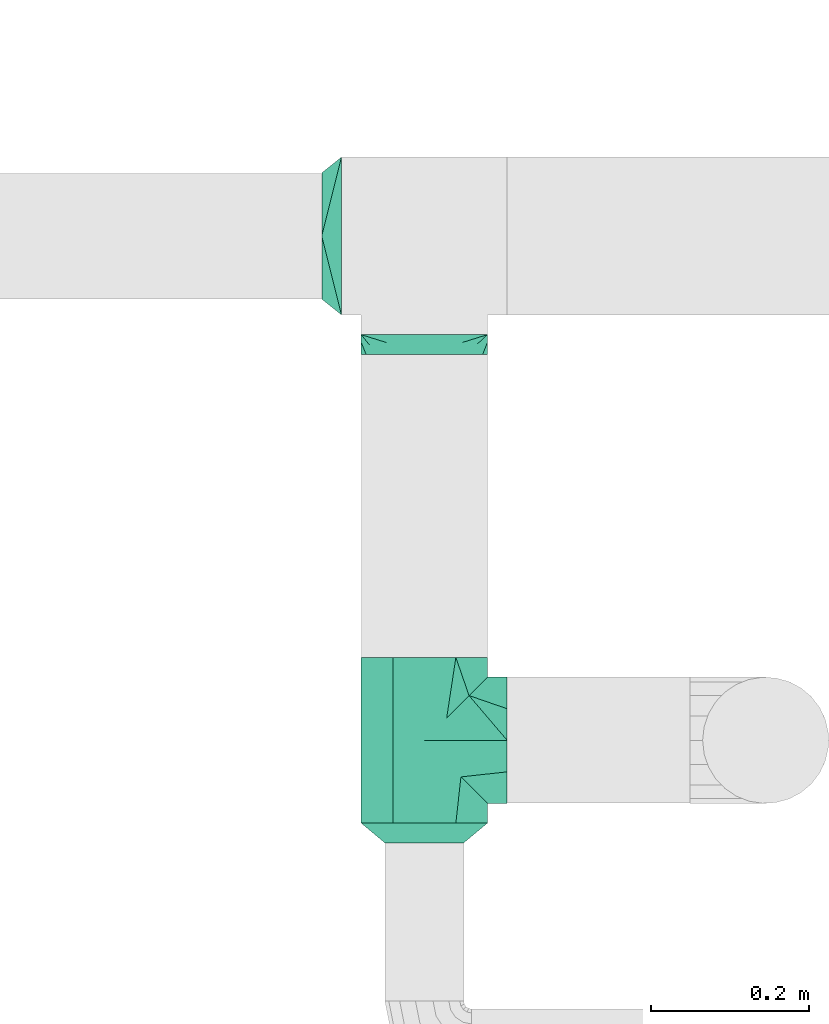
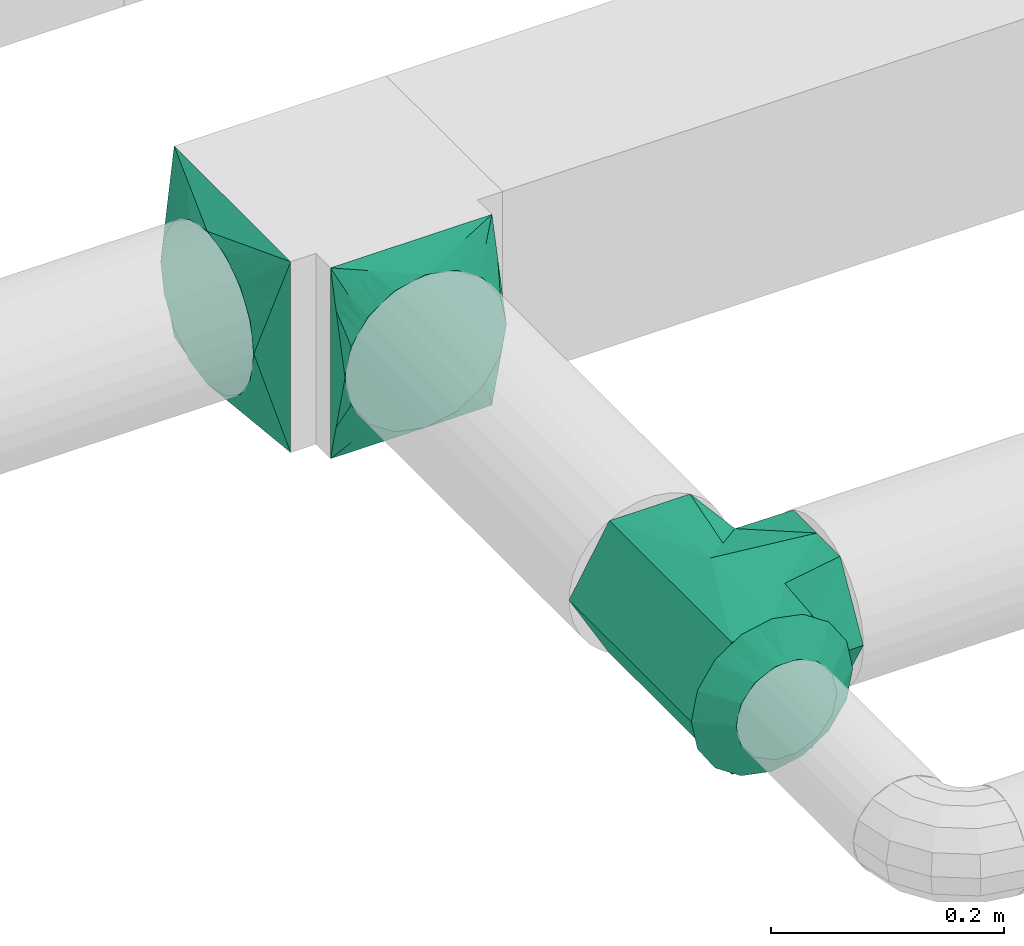
# One storey, part 3 of 5: 4 flow fittings.
"""IFC2X3 building model written with IfcOpenShell, lengths in millimetres."""

import ifcopenshell
import ifcopenshell.guid

model = None  # the IFC model being written
_history = None  # IfcOwnerHistory: only IFC2X3 demands one
_inside = {}  # id of a spatial element -> (the spatial element, [elements in it])
_under = {}  # id of a project, library or spatial element -> (it, [spatial elements below it])
_declared = {}  # id of a project -> (the project, [libraries it declares])
_typed = {}  # id of a type object -> (the type object, [elements of that type])
_made_of = {}  # id of a material, layer set ... -> (it, [elements and type objects made of it])


def new_model(schema):
    """Start an empty IFC model of exactly this schema.

    Asked for "IFC4X3", IfcOpenShell would pick the latest addendum, in which some entities
    have other attributes; the version numbers below select the first issue.
    IFC2X3 requires an IfcOwnerHistory on every rooted entity: one is made here for all.
    """
    global model, _history
    if schema == "IFC4X3":
        model = ifcopenshell.file(schema_version=(4, 3, 0, 0))
    else:
        model = ifcopenshell.file(schema=schema)
    _inside.clear()
    _under.clear()
    _declared.clear()
    _typed.clear()
    _made_of.clear()
    _history = None
    if model.schema == "IFC2X3":
        org = make("IfcOrganization", Name="unknown")
        user = make(
            "IfcPersonAndOrganization",
            ThePerson=make("IfcPerson", FamilyName="unknown"),
            TheOrganization=org,
        )
        app = make(
            "IfcApplication",
            ApplicationDeveloper=org,
            Version="unknown",
            ApplicationFullName="unknown",
            ApplicationIdentifier="unknown",
        )
        _history = make(
            "IfcOwnerHistory",
            OwningUser=user,
            OwningApplication=app,
            ChangeAction="ADDED",
            CreationDate=0,
        )
    return model


def make(cls, **values):
    """One entity of the class cls with the attributes given. An attribute that is None is left unset."""
    return model.create_entity(
        cls, **{name: value for name, value in values.items() if value is not None}
    )


def entity(cls, *values):
    """Any entity or typed value of the class cls, its attributes in the order of the schema. None: left unset."""
    e = model.create_entity(cls)
    for i, value in enumerate(values):
        if value is not None:
            e[i] = value
    return e


def rooted(cls, **values):
    """An entity with a GlobalId (a new one), such as an element, a storey or a relation."""
    return make(cls, GlobalId=ifcopenshell.guid.new(), OwnerHistory=_history, **values)


def si_unit(unit_type, name, prefix=None):
    """IfcSIUnit, for example si_unit("LENGTHUNIT", "METRE", prefix="MILLI")."""
    return make("IfcSIUnit", UnitType=unit_type, Prefix=prefix, Name=name)


def converted_unit(unit_type, name, factor, base, dimensions=None, offset=None):
    """IfcConversionBasedUnit, such as the inch: factor (a typed value) times the base unit."""
    return make(
        "IfcConversionBasedUnit"
        if offset is None
        else "IfcConversionBasedUnitWithOffset",
        ConversionOffset=offset,
        Dimensions=None
        if dimensions is None
        else entity("IfcDimensionalExponents", *dimensions),
        UnitType=unit_type,
        Name=name,
        ConversionFactor=make(
            "IfcMeasureWithUnit", ValueComponent=factor, UnitComponent=base
        ),
    )


def derived_unit(unit_type, elements):
    """IfcDerivedUnit: a product of units, each with its exponent."""
    return make(
        "IfcDerivedUnit",
        Elements=[
            make("IfcDerivedUnitElement", Unit=unit, Exponent=power)
            for unit, power in elements
        ],
        UnitType=unit_type,
    )


def assignment(units):
    """IfcUnitAssignment: the units of a project."""
    return None if units is None else make("IfcUnitAssignment", Units=units)


def point(xyz):
    """IfcCartesianPoint."""
    return None if xyz is None else make("IfcCartesianPoint", Coordinates=xyz)


def direction(xyz):
    """IfcDirection."""
    return None if xyz is None else make("IfcDirection", DirectionRatios=xyz)


def frame(location, z_axis=None, x_axis=None):
    """IfcAxis2Placement3D, a coordinate frame: its origin and axes. An axis left out is left unset."""
    return make(
        "IfcAxis2Placement3D",
        Location=point(location),
        Axis=direction(z_axis),
        RefDirection=direction(x_axis),
    )


def origin():
    """The frame at (0, 0, 0) with its axes left unset."""
    return frame((0.0, 0.0, 0.0))


def place(relative_to, where):
    """IfcLocalPlacement: puts the frame where relative to a parent placement (None: the world)."""
    return make(
        "IfcLocalPlacement", PlacementRelTo=relative_to, RelativePlacement=where
    )


def context(
    kind, dimensions, precision=None, world=None, true_north=None, identifier=None
):
    """IfcGeometricRepresentationContext, for example the 3D "Model" context."""
    return make(
        "IfcGeometricRepresentationContext",
        ContextIdentifier=identifier,
        ContextType=kind,
        CoordinateSpaceDimension=dimensions,
        Precision=precision,
        WorldCoordinateSystem=world,
        TrueNorth=true_north,
    )


def subcontext(parent, identifier, kind, view, scale=None):
    """IfcGeometricRepresentationSubContext, for example "Body" below "Model"."""
    return make(
        "IfcGeometricRepresentationSubContext",
        ContextIdentifier=identifier,
        ContextType=kind,
        ParentContext=parent,
        TargetScale=scale,
        TargetView=view,
    )


def project(units=None, contexts=None):
    """IfcProject with its units and contexts."""
    return rooted(
        "IfcProject",
        Name="project",
        RepresentationContexts=contexts,
        UnitsInContext=assignment(units),
    )


def spatial(cls, under=None, at=None, **own):
    """A site, building, storey or space (cls), placed at a placement, below another one or the project."""
    s = rooted(cls, ObjectPlacement=at, **own)
    if under is not None:
        _under.setdefault(under.id(), (under, []))[1].append(s)
    return s


def faces_of(points, faces, orient=None, outer=None):
    """IfcFace entities. A face is a list of loops; a loop is a list of indices into points, from 0.

    orient and outer hold one flag for each loop. By default every Orientation is true, the
    first loop of a face is its IfcFaceOuterBound and the others are IfcFaceBound.
    """
    made = []
    for i, loops in enumerate(faces):
        bounds = []
        for j, loop in enumerate(loops):
            is_outer = j == 0 if outer is None else outer[i][j]
            bounds.append(
                make(
                    "IfcFaceOuterBound" if is_outer else "IfcFaceBound",
                    Bound=make("IfcPolyLoop", Polygon=[points[k] for k in loop]),
                    Orientation=True if orient is None else orient[i][j],
                )
            )
        made.append(make("IfcFace", Bounds=bounds))
    return made


def faceted_brep(points, faces, orient=None, outer=None, voids=None):
    """IfcFacetedBrep: a solid bounded by flat faces; with voids (closed shells), ...WithVoids."""
    shared = [point(p) for p in points]
    hull = make("IfcClosedShell", CfsFaces=faces_of(shared, faces, orient, outer))
    if voids is None:
        return make("IfcFacetedBrep", Outer=hull)
    return make(
        "IfcFacetedBrepWithVoids",
        Outer=hull,
        Voids=[
            make(cls, CfsFaces=faces_of(shared, fs, o, b)) for cls, fs, o, b in voids
        ],
    )


def shape(context_of_items, identifier, shape_type, items):
    """IfcShapeRepresentation: the items that make up one representation, for example the "Body"."""
    return make(
        "IfcShapeRepresentation",
        ContextOfItems=context_of_items,
        RepresentationIdentifier=identifier,
        RepresentationType=shape_type,
        Items=items,
    )


def source(mapping_origin, context_of_items, identifier, shape_type, items):
    """IfcRepresentationMap: a shape defined once, which mapped items show again and again."""
    return make(
        "IfcRepresentationMap",
        MappingOrigin=mapping_origin,
        MappedRepresentation=shape(context_of_items, identifier, shape_type, items),
    )


def transform(
    local_origin,
    x_axis=None,
    y_axis=None,
    z_axis=None,
    scale=None,
    scale2=None,
    scale3=None,
    uniform=True,
):
    """IfcCartesianTransformationOperator3D, or its non-uniform kind. x_axis, y_axis, z_axis: its Axis1, 2, 3."""
    if uniform:
        return make(
            "IfcCartesianTransformationOperator3D",
            Axis1=direction(x_axis),
            Axis2=direction(y_axis),
            LocalOrigin=point(local_origin),
            Scale=scale,
            Axis3=direction(z_axis),
        )
    return make(
        "IfcCartesianTransformationOperator3DnonUniform",
        Axis1=direction(x_axis),
        Axis2=direction(y_axis),
        LocalOrigin=point(local_origin),
        Scale=scale,
        Axis3=direction(z_axis),
        Scale2=scale2,
        Scale3=scale3,
    )


def mapped(mapping_source, mapping_target):
    """IfcMappedItem: shows the shape of a source again, moved by a transform."""
    return make(
        "IfcMappedItem", MappingSource=mapping_source, MappingTarget=mapping_target
    )


def material(Name=None, Category=None):
    """IfcMaterial."""
    return make("IfcMaterial", Name=Name, Category=Category)


def material_list(materials):
    """IfcMaterialList."""
    return make("IfcMaterialList", Materials=materials)


def made_of(thing, what):
    """Note that an element or type object is made of a material, layer set ...; save() writes the relation."""
    if what is not None:
        _made_of.setdefault(what.id(), (what, []))[1].append(thing)
    return thing


def type_object(cls, material=None, **own):
    """A type object (cls), such as IfcWallType, which elements share."""
    return made_of(rooted(cls, **own), material)


def type_shapes(of_type, sources):
    """Give a type object the sources (RepresentationMaps) that its elements show as mapped items."""
    of_type.RepresentationMaps = sources


def element(
    cls,
    number,
    at=None,
    inside=None,
    cuts=None,
    type_object=None,
    material=None,
    context=None,
    identifier="Body",
    shape_type=None,
    held_by="IfcProductDefinitionShape",
    body=None,
    shapes=None,
    **own,
):
    """One element of the class cls, such as IfcWall. Its Tag is "e" and its number.

    at: its placement. inside: the storey or other place that contains it. cuts: it is an
    opening in that element (IfcRelVoidsElement). A single representation is given by context,
    identifier, shape_type and body (its items); several are given by shapes. held_by: the class
    of the entity that holds the representations. save() writes the other relations.
    """
    e = rooted(cls, Tag="e%d" % number, ObjectPlacement=at, **own)
    if body is not None:
        shapes = [shape(context, identifier, shape_type, body)]
    if shapes is not None:
        e.Representation = make(held_by, Representations=shapes)
    if inside is not None:
        _inside.setdefault(inside.id(), (inside, []))[1].append(e)
    if cuts is not None:
        rooted(
            "IfcRelVoidsElement", RelatingBuildingElement=cuts, RelatedOpeningElement=e
        )
    if type_object is not None:
        _typed.setdefault(type_object.id(), (type_object, []))[1].append(e)
    return made_of(e, material)


def aggregate(whole, parts):
    """IfcRelAggregates: a whole, such as a stair, and the parts it consists of."""
    return rooted("IfcRelAggregates", RelatingObject=whole, RelatedObjects=parts)


def save(model, path):
    """Write the relations noted so far, then the file.

    IfcRelAggregates (storeys below a building ...), IfcRelContainedInSpatialStructure (elements
    in a storey), IfcRelDefinesByType, IfcRelAssociatesMaterial and IfcRelDeclares: one each for
    every whole, place, type object, material and project.
    """
    for whole, parts in _under.values():
        aggregate(whole, parts)
    for where, things in _inside.values():
        rooted(
            "IfcRelContainedInSpatialStructure",
            RelatedElements=things,
            RelatingStructure=where,
        )
    for kind, things in _typed.values():
        rooted("IfcRelDefinesByType", RelatedObjects=things, RelatingType=kind)
    for what, things in _made_of.values():
        rooted("IfcRelAssociatesMaterial", RelatedObjects=things, RelatingMaterial=what)
    for by, libraries in _declared.values():
        rooted("IfcRelDeclares", RelatingContext=by, RelatedDefinitions=libraries)
    model.write(path)


model = new_model("IFC2X3")

# Units and contexts
model_context = context("Model", 3, precision=0.01, world=origin(), true_north=direction((6.12303176911189e-17, 1.0)))
body_context = subcontext(model_context, "Body", "Model", "MODEL_VIEW")
ifc_project = project(units=[si_unit("LENGTHUNIT", "METRE", prefix="MILLI"), si_unit("AREAUNIT", "SQUARE_METRE"), si_unit("VOLUMEUNIT", "CUBIC_METRE"), converted_unit("PLANEANGLEUNIT", "DEGREE", entity("IfcRatioMeasure", 0.0174532925199433), si_unit("PLANEANGLEUNIT", "RADIAN"), dimensions=[0, 0, 0, 0, 0, 0, 0]), si_unit("MASSUNIT", "GRAM", prefix="KILO"), derived_unit("MASSDENSITYUNIT", [(si_unit("MASSUNIT", "GRAM", prefix="KILO"), 1), (si_unit("LENGTHUNIT", "METRE"), -3)]), derived_unit("MOMENTOFINERTIAUNIT", [(si_unit("LENGTHUNIT", "METRE"), 4)]), si_unit("TIMEUNIT", "SECOND"), si_unit("FREQUENCYUNIT", "HERTZ"), si_unit("THERMODYNAMICTEMPERATUREUNIT", "DEGREE_CELSIUS"), derived_unit("THERMALTRANSMITTANCEUNIT", [(si_unit("MASSUNIT", "GRAM", prefix="KILO"), 1), (si_unit("THERMODYNAMICTEMPERATUREUNIT", "KELVIN"), -1), (si_unit("TIMEUNIT", "SECOND"), -3)]), derived_unit("VOLUMETRICFLOWRATEUNIT", [(si_unit("LENGTHUNIT", "METRE"), 3), (si_unit("TIMEUNIT", "SECOND"), -1)]), si_unit("ELECTRICCURRENTUNIT", "AMPERE"), si_unit("ELECTRICVOLTAGEUNIT", "VOLT"), si_unit("POWERUNIT", "WATT"), si_unit("FORCEUNIT", "NEWTON", prefix="KILO"), si_unit("ILLUMINANCEUNIT", "LUX"), si_unit("LUMINOUSFLUXUNIT", "LUMEN"), si_unit("LUMINOUSINTENSITYUNIT", "CANDELA"), derived_unit("USERDEFINED", [(si_unit("MASSUNIT", "GRAM", prefix="KILO"), -1), (si_unit("LENGTHUNIT", "METRE"), -2), (si_unit("TIMEUNIT", "SECOND"), 3), (si_unit("LUMINOUSFLUXUNIT", "LUMEN"), 1)]), derived_unit("LINEARVELOCITYUNIT", [(si_unit("LENGTHUNIT", "METRE"), 1), (si_unit("TIMEUNIT", "SECOND"), -1)]), si_unit("PRESSUREUNIT", "PASCAL"), derived_unit("USERDEFINED", [(si_unit("LENGTHUNIT", "METRE"), -2), (si_unit("MASSUNIT", "GRAM", prefix="KILO"), 1), (si_unit("TIMEUNIT", "SECOND"), -2)]), derived_unit("LINEARFORCEUNIT", [(si_unit("MASSUNIT", "GRAM", prefix="KILO"), 1), (si_unit("LENGTHUNIT", "METRE"), 1), (si_unit("TIMEUNIT", "SECOND"), -2), (si_unit("LENGTHUNIT", "METRE"), -1)]), derived_unit("PLANARFORCEUNIT", [(si_unit("MASSUNIT", "GRAM", prefix="KILO"), 1), (si_unit("LENGTHUNIT", "METRE"), 1), (si_unit("TIMEUNIT", "SECOND"), -2), (si_unit("LENGTHUNIT", "METRE"), -2)])], contexts=[model_context])

# Site, building, storey
site_placement = place(None, origin())
site = spatial("IfcSite", under=ifc_project, at=site_placement, CompositionType="ELEMENT")
building_placement = place(site_placement, origin())
building = spatial("IfcBuilding", under=site, at=building_placement, CompositionType="ELEMENT")
storey_placement = place(building_placement, frame((0.0, 0.0, 12000.0)))
storey = spatial("IfcBuildingStorey", under=building, at=storey_placement, Name="03 Level", CompositionType="ELEMENT", Elevation=12000.0)

# Flow fittings
duct_fitting_type_1 = type_object("IfcDuctFittingType", Name="tee_90_001:Air_Tee 90_Circ", PredefinedType="NOTDEFINED")
shared_shape_1 = source(origin(), body_context, "Body", "Brep", [
    faceted_brep([(-105.0, -80.0, 0.0), (-105.0, -60.0, 34.6410161513772), (-105.0, -40.0, 69.2820323027547), (-105.0, 0.0, 69.2820323027551), (-105.0, 40.0, 69.2820323027556), (-105.0, 60.0, 34.6410161513782), (-105.0, 80.0, 0.0), (-105.0, 60.0, -34.6410161513775), (-105.0, 40.0, -69.2820323027551), (-105.0, 0.0, -69.2820323027551), (-105.0, -40.0, -69.2820323027552), (-105.0, -50.0, -51.9615242270664), (-105.0, -60.0, -34.6410161513777), (-105.0, -70.0, -17.320508075689), (105.0, 40.0, -69.2820323027551), (105.0, 60.0, -34.6410161513775), (105.0, 80.0, 0.0), (105.0, 65.7984888459214, 24.5977388631197), (105.0, 40.0, 69.2820323027556), (105.0, 0.0, 69.2820323027551), (105.0, -40.0, 69.2820323027547), (105.0, -50.0, 51.9615242270659), (105.0, -60.0, 34.6410161513772), (105.0, -70.0, 17.3205080756885), (105.0, -80.0, 0.0), (105.0, -60.0, -34.6410161513777), (105.0, -40.0, -69.2820323027552), (105.0, 0.0, -69.2820323027551), (68.3421278184577, -68.342127818458, 28.2262960857814), (56.6842556369154, -56.6842556369157, 56.452592171563), (28.3421278184577, -28.3421278184583, 68.2262960857815), (0.0, 0.0, 80.0), (-63.1985060310392, -63.1985060310391, 32.5857226086492), (-46.3970120620785, -46.3970120620784, 65.1714452172985), (74.1710639092289, -74.1710639092292, 14.1131480428905), (-80.0, -80.0, 0.0), (-71.5992530155196, -71.5992530155195, 16.2928613043245), (69.3533420594162, -69.3533420594165, 25.7779219633887), (80.0, -80.0, 0.0), (-56.6842556369153, -56.6842556369152, -56.4525921715632), (-74.1710639092288, -74.1710639092287, -14.1131480428909), (0.0, 0.0, -80.0), (46.3970120620782, -46.3970120620784, -65.1714452172987), (-68.3421278184577, -68.3421278184575, -28.2262960857817), (-69.3533413785283, -69.3533413785281, -25.7779236119694), (71.5992530155195, -71.5992530155198, -16.2928613043245), (63.1985060310391, -63.1985060310394, -32.5857226086495), (-28.3421278184577, -28.3421278184578, -68.2262960857816), (40.0, -105.0, -69.2820323027551), (65.798488718459, -105.0, -24.5977390838916), (80.0, -105.0, 0.0), (70.0, -105.0, 17.3205080756893), (60.0, -105.0, 34.641016151378), (40.0, -105.0, 69.2820323027556), (0.0, -105.0, 69.2820323027551), (-40.0, -105.0, 69.2820323027547), (-65.7984888630516, -105.0, 24.5977388334501), (-80.0, -105.0, 0.0), (-70.0, -105.0, -17.320508075689), (-60.0, -105.0, -34.6410161513777), (-40.0, -105.0, -69.2820323027552), (0.0, -105.0, -69.2820323027551)], [[[0, 1, 2, 3, 4, 5, 6, 7, 8, 9, 10, 11, 12, 13]], [[14, 15, 16, 17, 18, 19, 20, 21, 22, 23, 24, 25, 26, 27]], [[28, 23, 22]], [[29, 22, 21, 20]], [[19, 30, 20]], [[30, 19, 31]], [[32, 33, 1]], [[34, 24, 23]], [[33, 2, 1]], [[0, 35, 36, 32]], [[20, 30, 29]], [[0, 32, 1]], [[31, 19, 18]], [[17, 16, 6, 5, 4, 18]], [[33, 3, 2]], [[33, 31, 3]], [[23, 28, 37, 34]], [[4, 31, 18]], [[24, 34, 38]], [[31, 4, 3]], [[22, 29, 28]], [[14, 8, 7, 6, 16, 15]], [[39, 12, 11, 10]], [[40, 0, 13]], [[8, 14, 41]], [[42, 26, 25]], [[9, 8, 41]], [[12, 39, 43]], [[27, 26, 42]], [[13, 43, 44, 40]], [[24, 38, 45, 46]], [[0, 40, 35]], [[24, 46, 25]], [[25, 46, 42]], [[39, 10, 47]], [[47, 9, 41]], [[12, 43, 13]], [[9, 47, 10]], [[41, 14, 27]], [[42, 41, 27]], [[48, 49, 50, 51, 52, 53, 54, 55, 56, 57, 58, 59, 60, 61]], [[32, 55, 33]], [[57, 56, 36]], [[36, 35, 57]], [[33, 55, 54]], [[56, 32, 36]], [[51, 50, 38]], [[54, 29, 30, 31]], [[55, 32, 56]], [[33, 54, 31]], [[52, 29, 53]], [[52, 37, 28, 29]], [[37, 52, 51]], [[54, 53, 29]], [[51, 38, 34, 37]], [[46, 48, 42]], [[58, 35, 40, 44]], [[48, 46, 49]], [[45, 38, 50]], [[42, 48, 61]], [[59, 44, 43, 39]], [[58, 57, 35]], [[50, 49, 45]], [[49, 46, 45]], [[42, 61, 41]], [[59, 39, 60]], [[61, 39, 47, 41]], [[61, 60, 39]], [[44, 59, 58]]]),
])
type_shapes(duct_fitting_type_1, [shared_shape_1])
flow_fitting_1_placement = place(storey_placement, frame((23185.9900708518, -69795.234231492, 3000.0), z_axis=(0.0, 0.0, 1.0), x_axis=(0.0, 1.0, 0.0)))
element("IfcFlowFitting", 1, at=flow_fitting_1_placement, inside=storey, type_object=duct_fitting_type_1, Name="tee_90_001:Air_Tee 90_Circ", ObjectType="tee_90_001:Air_Tee 90_Circ", context=body_context, shape_type="MappedRepresentation", body=[
    mapped(shared_shape_1, transform((0.0, 0.0, 0.0), scale=1.0)),
])
ifc_material_1 = material(Name="Material_Duct")
ifc_material_2 = material(Name="Material_Lining")
ifc_material_3 = material(Name="Material_Ins")
ifc_material_list_1 = material_list([ifc_material_1, ifc_material_2, ifc_material_3])
duct_fitting_type_2 = type_object("IfcDuctFittingType", Name="reduction_001:Air_Reduction_Circ", PredefinedType="NOTDEFINED", material=ifc_material_list_1)
shared_shape_2 = source(origin(), body_context, "Body", "Brep", [
    faceted_brep([(25.0, -50.0, 0.0), (25.0, -47.5242216975607, -10.8470934779334), (25.0, -45.0484433951223, -21.6941869558729), (25.0, -38.1114667440304, -30.3928805396358), (25.0, -31.1744900929385, -39.0915741233988), (25.0, -21.1502683953773, -43.9189848662444), (25.0, -11.1260466978161, -48.74639560909), (25.0, 0.0, -48.7463956090899), (25.0, 11.1260466978174, -48.7463956090898), (25.0, 21.1502683953783, -43.9189848662439), (25.0, 31.1744900929393, -39.0915741233981), (25.0, 38.1114667440309, -30.3928805396354), (25.0, 45.0484433951224, -21.6941869558726), (25.0, 47.5242216975608, -10.8470934779335), (25.0, 50.0, 0.0), (25.0, 47.5242216975603, 10.8470934779443), (25.0, 45.0484433951197, 21.6941869558827), (25.0, 38.1114667440274, 30.3928805396434), (25.0, 31.1744900929351, 39.0915741234041), (25.0, 21.1502683953754, 43.9189848662482), (25.0, 11.1260466978156, 48.7463956090923), (25.0, 0.0, 48.7463956090925), (25.0, -11.1260466978137, 48.7463956090927), (25.0, -21.1502683953737, 43.9189848662489), (25.0, -31.1744900929338, 39.0915741234051), (25.0, -38.1114667440265, 30.3928805396443), (25.0, -45.0484433951193, 21.6941869558836), (25.0, -47.5242216975601, 10.8470934779448), (0.0, 80.0, 0.0), (0.0, 76.9551813004502, -15.3073372946042), (0.0, 73.9103626009034, -30.6146745892079), (0.0, 65.2394525479148, -43.5916085420674), (0.0, 56.5685424949263, -56.568542494927), (0.0, 43.5916085420678, -65.239452547918), (0.0, 30.6146745892093, -73.9103626009091), (0.0, 15.3073372946045, -76.9551813004584), (0.0, 0.0, -80.0), (0.0, -15.3073372946054, -76.9551813004588), (0.0, -30.6146745892104, -73.9103626009099), (0.0, -43.5916085420694, -65.2394525479189), (0.0, -56.5685424949284, -56.5685424949279), (0.0, -65.2394525479173, -43.5916085420681), (0.0, -73.9103626009062, -30.6146745892082), (0.0, -76.9551813004531, -15.307337294604), (0.0, -80.0, 0.0), (0.0, -76.9551813004526, 15.3073372946037), (0.0, -73.9103626009022, 30.6146745892071), (0.0, -65.2394525479115, 43.5916085420641), (0.0, -56.5685424949208, 56.5685424949211), (0.0, -43.5916085420627, 65.2394525479091), (0.0, -30.6146745892045, 73.910362600897), (0.0, -15.3073372946022, 76.9551813004446), (0.0, 0.0, 80.0), (0.0, 15.3073372946022, 76.955181300444), (0.0, 30.6146745892043, 73.9103626008959), (0.0, 43.5916085420619, 65.2394525479076), (0.0, 56.5685424949195, 56.5685424949194), (0.0, 65.2394525479096, 43.5916085420626), (0.0, 73.9103626008998, 30.6146745892058), (0.0, 76.9551813004499, 15.3073372946029)], [[[0, 1, 2, 3, 4, 5, 6, 7, 8, 9, 10, 11, 12, 13, 14, 15, 16, 17, 18, 19, 20, 21, 22, 23, 24, 25, 26, 27]], [[28, 29, 30, 31, 32, 33, 34, 35, 36, 37, 38, 39, 40, 41, 42, 43, 44, 45, 46, 47, 48, 49, 50, 51, 52, 53, 54, 55, 56, 57, 58, 59]], [[12, 30, 13]], [[33, 9, 34]], [[31, 30, 12]], [[41, 40, 3]], [[6, 37, 7]], [[7, 35, 8]], [[4, 40, 39]], [[12, 11, 31]], [[14, 29, 28]], [[36, 7, 37]], [[9, 33, 10]], [[14, 13, 29]], [[34, 9, 8]], [[5, 4, 39]], [[0, 43, 1]], [[41, 2, 42]], [[6, 38, 37]], [[11, 32, 31]], [[11, 10, 32]], [[5, 38, 6]], [[39, 38, 5]], [[2, 41, 3]], [[13, 30, 29]], [[40, 4, 3]], [[1, 42, 2]], [[35, 34, 8]], [[43, 0, 44]], [[35, 7, 36]], [[43, 42, 1]], [[33, 32, 10]], [[26, 46, 27]], [[49, 23, 50]], [[47, 46, 26]], [[57, 56, 17]], [[20, 53, 21]], [[21, 51, 22]], [[18, 56, 55]], [[26, 25, 47]], [[0, 45, 44]], [[52, 21, 53]], [[23, 49, 24]], [[0, 27, 45]], [[50, 23, 22]], [[19, 18, 55]], [[14, 59, 15]], [[57, 16, 58]], [[20, 54, 53]], [[25, 48, 47]], [[25, 24, 48]], [[19, 54, 20]], [[55, 54, 19]], [[16, 57, 17]], [[27, 46, 45]], [[56, 18, 17]], [[15, 58, 16]], [[51, 50, 22]], [[59, 14, 28]], [[51, 21, 52]], [[59, 58, 15]], [[49, 48, 24]]]),
])
type_shapes(duct_fitting_type_2, [shared_shape_2])
flow_fitting_2_placement = place(storey_placement, frame((23185.9900708518, -69900.234231492, 3000.0), z_axis=(0.0, 0.0, 1.0), x_axis=(0.0, -1.0, 0.0)))
element("IfcFlowFitting", 2, at=flow_fitting_2_placement, inside=storey, type_object=duct_fitting_type_2, material=ifc_material_1, Name="reduction_001:Air_Reduction_Circ", ObjectType="reduction_001:Air_Reduction_Circ", context=body_context, shape_type="MappedRepresentation", body=[
    mapped(shared_shape_2, transform((0.0, 0.0, 0.0), scale=1.0)),
])
ifc_material_list_2 = material_list([ifc_material_2, ifc_material_1, ifc_material_3])
duct_fitting_type_3 = type_object("IfcDuctFittingType", Name="multi_shape_trans_001:Air_Multi shape transition_Circ", PredefinedType="NOTDEFINED", material=ifc_material_list_2)
shared_shape_3 = source(origin(), body_context, "Body", "Brep", [
    faceted_brep([(25.0, -30.614674589207, -73.9103626009021), (25.0, -22.8665162204521, -75.4515671248636), (25.0, -15.1183578516973, -76.9927716488251), (25.0, -11.3387683887729, -77.7445787366186), (25.0, -7.55917892584856, -78.4963858244121), (25.0, 0.0, -80.0), (25.0, 7.55917891579331, -78.4963858264122), (25.0, 15.1183578315867, -76.9927716528254), (25.0, 18.9924370209918, -76.2221693898446), (25.0, 22.8665162103969, -75.4515671268637), (25.0, 30.6146745892071, -73.9103626009021), (25.0, 37.1031415656363, -69.5749075744073), (25.0, 43.5916085420654, -65.2394525479125), (25.0, 50.0800755184946, -60.9039975214177), (25.0, 56.5685424949238, -56.5685424949229), (25.0, 60.9039975214186, -50.0800755184938), (25.0, 65.2394525479134, -43.5916085420646), (25.0, 69.5749075744082, -37.1031415656355), (25.0, 73.910362600903, -30.6146745892063), (25.0, 75.4515671248645, -22.8665162204514), (25.0, 76.992771648826, -15.1183578516966), (25.0, 77.7445787366195, -11.3387683887722), (25.0, 78.496385824413, -7.55917892584782), (25.0, 80.0, 0.0), (25.0, 78.4963858264131, 7.55917891579322), (25.0, 76.9927716528263, 15.1183578315867), (25.0, 76.2221693898455, 18.9924370209917), (25.0, 75.4515671268647, 22.8665162103968), (25.0, 73.910362600903, 30.614674589207), (25.0, 69.5749075744082, 37.1031415656362), (25.0, 65.2394525479135, 43.5916085420653), (25.0, 60.9039975214187, 50.0800755184945), (25.0, 56.5685424949239, 56.5685424949237), (25.0, 50.0800755184948, 60.9039975214185), (25.0, 43.5916085420656, 65.2394525479133), (25.0, 37.1031415656365, 69.5749075744081), (25.0, 30.6146745892073, 73.9103626009029), (25.0, 22.8665162204525, 75.4515671248644), (25.0, 15.1183578516976, 76.992771648826), (25.0, 11.3387683887732, 77.7445787366195), (25.0, 7.55917892584888, 78.496385824413), (25.0, 0.0, 80.0), (25.0, -7.55917891579327, 78.4963858264132), (25.0, -15.1183578315867, 76.9927716528263), (25.0, -18.9924370209918, 76.2221693898455), (25.0, -22.8665162103969, 75.4515671268647), (25.0, -30.6146745892071, 73.910362600903), (25.0, -37.1031415656362, 69.5749075744082), (25.0, -43.5916085420654, 65.2394525479134), (25.0, -50.0800755184946, 60.9039975214187), (25.0, -56.5685424949237, 56.5685424949239), (25.0, -60.9039975214185, 50.0800755184947), (25.0, -65.2394525479133, 43.5916085420656), (25.0, -69.5749075744081, 37.1031415656364), (25.0, -73.9103626009029, 30.6146745892072), (25.0, -75.4515671248645, 22.8665162204524), (25.0, -76.992771648826, 15.1183578516975), (25.0, -77.7445787366195, 11.3387683887731), (25.0, -78.496385824413, 7.55917892584876), (25.0, -80.0, 0.0), (25.0, -78.4963858264131, -7.55917891579276), (25.0, -76.9927716528262, -15.1183578315862), (25.0, -76.2221693898453, -18.9924370209913), (25.0, -75.4515671268645, -22.8665162103963), (25.0, -73.9103626009028, -30.6146745892065), (25.0, -69.574907574408, -37.1031415656356), (25.0, -65.2394525479132, -43.5916085420648), (25.0, -60.9039975214184, -50.0800755184939), (25.0, -56.5685424949236, -56.5685424949231), (25.0, -50.0800755184945, -60.9039975214178), (25.0, -43.5916085420653, -65.2394525479126), (25.0, -37.1031415656362, -69.5749075744073), (0.0, -80.0, 100.0), (0.0, 80.0, 100.0), (0.0, 80.0, -100.0), (0.0, -80.0, -100.0), (6.50713916945186, -59.1771546577547, 94.7942886644397), (9.76070875417778, -48.7657319866316, 92.1914329966587), (22.0035695847259, -9.588577328877, 82.3971443322195), (19.0071391694519, -19.1771546577542, 84.7942886644389), (16.0107087541778, -28.7657319866313, 87.1914329966584), (13.0142783389037, -38.3543093155085, 89.5885773288778), (12.5000000004112, -69.9443399352347, 76.5204921859004), (9.76070845754317, -80.0, 60.9571661698283), (13.0142779433909, -80.0, 47.9428882264372), (16.0107084575432, -80.0, 35.9571661698279), (19.0071389716954, -80.0, 23.9714441132186), (20.5053542287716, -80.0, 17.978583084914), (22.0035694858477, -80.0, 11.9857220566093), (3.25356948584772, -80.0, 86.9857220566105), (6.50713897169544, -80.0, 73.9714441132194), (3.25356958472593, -69.5885773288778, 97.3971443322206), (3.25356958472592, -80.0, -86.9857216610962), (6.50713916945185, -80.0, -73.9714433221924), (9.76070875417777, -80.0, -60.9571649832887), (13.0142783389037, -80.0, -47.9428866443849), (16.0107087541778, -80.0, -35.9571649832885), (19.0071391694518, -80.0, -23.9714433221921), (22.0035695847259, -80.0, -11.9857216610957), (12.5000000004112, -66.5204921862289, -79.9443399349049), (9.76070845754315, -48.7657329358624, -92.1914332339651), (13.0142779433909, -38.3543105811496, -89.5885776452868), (16.0107084575432, -28.7657329358621, -87.1914332339649), (19.0071389716954, -19.1771552905747, -84.794288822643), (20.5053542287716, -14.382866467931, -83.595716616982), (22.0035694858477, -9.58857764528725, -82.397144411321), (3.25356948584772, -69.5885776452881, -97.3971444113217), (6.50713897169543, -59.1771552905752, -94.7942888226434), (3.25356958472593, 69.5885773288765, -97.3971443322191), (6.50713916945186, 59.1771546577536, -94.7942886644383), (9.76070875417778, 48.7657319866307, -92.1914329966574), (13.0142783389037, 38.3543093155078, -89.5885773288765), (16.0107087541778, 28.7657319866308, -87.1914329966572), (19.0071391694519, 19.1771546577538, -84.7942886644378), (22.0035695847259, 9.58857732887686, -82.3971443322185), (12.5000000004112, 69.9443399352339, -76.5204921858991), (9.76070845754317, 80.0, -60.957166169827), (13.0142779433909, 80.0, -47.942888226436), (16.0107084575432, 80.0, -35.9571661698268), (19.0071389716954, 80.0, -23.9714441132175), (20.5053542287716, 80.0, -17.9785830849129), (22.0035694858477, 80.0, -11.9857220566083), (3.25356948584772, 80.0, -86.985722056609), (6.50713897169544, 80.0, -73.971444113218), (3.25356958472593, 80.0, 86.9857216610977), (6.50713916945185, 80.0, 73.9714433221937), (9.76070875417778, 80.0, 60.9571649832898), (13.0142783389037, 80.0, 47.9428866443859), (16.0107087541778, 80.0, 35.9571649832893), (19.0071391694519, 80.0, 23.9714433221928), (22.0035695847259, 80.0, 11.9857216610963), (12.5000000004112, 66.5204921862283, 79.9443399349061), (9.76070845754316, 48.7657329358616, 92.1914332339665), (13.0142779433909, 38.354310581149, 89.5885776452881), (16.0107084575432, 28.7657329358618, 87.191433233966), (19.0071389716954, 19.1771552905745, 84.794288822644), (20.5053542287716, 14.3828664679309, 83.595716616983), (22.0035694858477, 9.58857764528735, 82.397144411322), (3.25356948584772, 69.5885776452868, 97.3971444113232), (6.50713897169544, 59.1771552905742, 94.7942888226448)], [[[0, 1, 2, 3, 4, 5, 6, 7, 8, 9, 10, 11, 12, 13, 14, 15, 16, 17, 18, 19, 20, 21, 22, 23, 24, 25, 26, 27, 28, 29, 30, 31, 32, 33, 34, 35, 36, 37, 38, 39, 40, 41, 42, 43, 44, 45, 46, 47, 48, 49, 50, 51, 52, 53, 54, 55, 56, 57, 58, 59, 60, 61, 62, 63, 64, 65, 66, 67, 68, 69, 70, 71]], [[72, 73, 74, 75]], [[76, 48, 77]], [[48, 47, 46, 77]], [[78, 79, 80, 81, 77, 46, 45, 44, 43, 42, 41]], [[49, 82, 50]], [[56, 55, 54, 83, 84, 85, 86, 87, 88, 59, 58, 57]], [[82, 72, 89]], [[82, 51, 50]], [[83, 52, 90]], [[91, 72, 82]], [[54, 53, 52, 83]], [[90, 52, 51]], [[51, 82, 89]], [[90, 51, 89]], [[76, 49, 48]], [[49, 76, 91]], [[82, 49, 91]], [[88, 87, 86, 85, 84, 83, 90, 89, 72, 75, 92, 93, 94, 95, 96, 97, 98, 59]], [[93, 66, 94]], [[66, 65, 64, 94]], [[98, 97, 96, 95, 94, 64, 63, 62, 61, 60, 59]], [[67, 99, 68]], [[2, 1, 0, 100, 101, 102, 103, 104, 105, 5, 4, 3]], [[99, 75, 106]], [[99, 69, 68]], [[100, 70, 107]], [[92, 75, 99]], [[0, 71, 70, 100]], [[107, 70, 69]], [[69, 99, 106]], [[107, 69, 106]], [[93, 67, 66]], [[67, 93, 92]], [[99, 67, 92]], [[105, 104, 103, 102, 101, 100, 107, 106, 75, 74, 108, 109, 110, 111, 112, 113, 114, 5]], [[109, 12, 110]], [[12, 11, 10, 110]], [[114, 113, 112, 111, 110, 10, 9, 8, 7, 6, 5]], [[13, 115, 14]], [[20, 19, 18, 116, 117, 118, 119, 120, 121, 23, 22, 21]], [[115, 74, 122]], [[115, 15, 14]], [[116, 16, 123]], [[108, 74, 115]], [[18, 17, 16, 116]], [[123, 16, 15]], [[15, 115, 122]], [[123, 15, 122]], [[109, 13, 12]], [[13, 109, 108]], [[115, 13, 108]], [[74, 73, 124, 125, 126, 127, 128, 129, 130, 23, 121, 120, 119, 118, 117, 116, 123, 122]], [[125, 30, 126]], [[30, 29, 28, 126]], [[130, 129, 128, 127, 126, 28, 27, 26, 25, 24, 23]], [[31, 131, 32]], [[38, 37, 36, 132, 133, 134, 135, 136, 137, 41, 40, 39]], [[131, 73, 138]], [[131, 33, 32]], [[132, 34, 139]], [[124, 73, 131]], [[36, 35, 34, 132]], [[139, 34, 33]], [[33, 131, 138]], [[139, 33, 138]], [[125, 31, 30]], [[31, 125, 124]], [[131, 31, 124]], [[73, 72, 91, 76, 77, 81, 80, 79, 78, 41, 137, 136, 135, 134, 133, 132, 139, 138]]]),
])
type_shapes(duct_fitting_type_3, [shared_shape_3])
flow_fitting_3_placement = place(storey_placement, frame((23185.9900708518, -69281.0352293172, 3000.0), z_axis=(0.0, 0.0, 1.0), x_axis=(0.0, -1.0, 0.0)))
element("IfcFlowFitting", 3, at=flow_fitting_3_placement, inside=storey, type_object=duct_fitting_type_3, material=ifc_material_1, Name="multi_shape_trans_001:Air_Multi shape transition_Circ", ObjectType="multi_shape_trans_001:Air_Multi shape transition_Circ", context=body_context, shape_type="MappedRepresentation", body=[
    mapped(shared_shape_3, transform((0.0, 0.0, 0.0), scale=1.0)),
])
ifc_material_list_3 = material_list([ifc_material_3, ifc_material_2, ifc_material_1])
duct_fitting_type_4 = type_object("IfcDuctFittingType", Name="multi_shape_trans_001:Air_Multi shape transition_Circ", PredefinedType="NOTDEFINED", material=ifc_material_list_3)
shared_shape_4 = source(origin(), body_context, "Body", "Brep", [
    faceted_brep([(25.0, -30.614674589207, -73.9103626009021), (25.0, -22.8665162204521, -75.4515671248636), (25.0, -15.1183578516973, -76.9927716488251), (25.0, -11.3387683887729, -77.7445787366186), (25.0, -7.55917892584856, -78.4963858244121), (25.0, 0.0, -80.0), (25.0, 7.55917891579331, -78.4963858264122), (25.0, 15.1183578315867, -76.9927716528254), (25.0, 18.9924370209918, -76.2221693898445), (25.0, 22.8665162103969, -75.4515671268637), (25.0, 30.6146745892071, -73.9103626009021), (25.0, 37.1031415656363, -69.5749075744073), (25.0, 43.5916085420654, -65.2394525479125), (25.0, 50.0800755184946, -60.9039975214177), (25.0, 56.5685424949238, -56.5685424949229), (25.0, 60.9039975214186, -50.0800755184938), (25.0, 65.2394525479134, -43.5916085420646), (25.0, 69.5749075744082, -37.1031415656355), (25.0, 73.910362600903, -30.6146745892063), (25.0, 75.4515671248645, -22.8665162204514), (25.0, 76.992771648826, -15.1183578516966), (25.0, 77.7445787366195, -11.3387683887722), (25.0, 78.496385824413, -7.55917892584782), (25.0, 80.0, 0.0), (25.0, 78.4963858264131, 7.55917891579322), (25.0, 76.9927716528263, 15.1183578315867), (25.0, 76.2221693898455, 18.9924370209917), (25.0, 75.4515671268647, 22.8665162103968), (25.0, 73.910362600903, 30.614674589207), (25.0, 69.5749075744082, 37.1031415656362), (25.0, 65.2394525479135, 43.5916085420653), (25.0, 60.9039975214187, 50.0800755184945), (25.0, 56.5685424949239, 56.5685424949237), (25.0, 50.0800755184948, 60.9039975214185), (25.0, 43.5916085420656, 65.2394525479133), (25.0, 37.1031415656365, 69.5749075744081), (25.0, 30.6146745892073, 73.9103626009029), (25.0, 22.8665162204525, 75.4515671248644), (25.0, 15.1183578516976, 76.992771648826), (25.0, 11.3387683887732, 77.7445787366195), (25.0, 7.55917892584888, 78.496385824413), (25.0, 0.0, 80.0), (25.0, -7.55917891579326, 78.4963858264132), (25.0, -15.1183578315867, 76.9927716528263), (25.0, -18.9924370209918, 76.2221693898455), (25.0, -22.8665162103969, 75.4515671268647), (25.0, -30.6146745892071, 73.910362600903), (25.0, -37.1031415656362, 69.5749075744082), (25.0, -43.5916085420654, 65.2394525479134), (25.0, -50.0800755184946, 60.9039975214187), (25.0, -56.5685424949237, 56.5685424949239), (25.0, -60.9039975214185, 50.0800755184947), (25.0, -65.2394525479133, 43.5916085420656), (25.0, -69.5749075744081, 37.1031415656364), (25.0, -73.9103626009029, 30.6146745892072), (25.0, -75.4515671248645, 22.8665162204524), (25.0, -76.992771648826, 15.1183578516975), (25.0, -77.7445787366195, 11.3387683887731), (25.0, -78.496385824413, 7.55917892584876), (25.0, -80.0, 0.0), (25.0, -78.4963858264131, -7.55917891579276), (25.0, -76.9927716528262, -15.1183578315862), (25.0, -76.2221693898453, -18.9924370209913), (25.0, -75.4515671268645, -22.8665162103963), (25.0, -73.9103626009028, -30.6146745892065), (25.0, -69.574907574408, -37.1031415656356), (25.0, -65.2394525479132, -43.5916085420648), (25.0, -60.9039975214184, -50.0800755184939), (25.0, -56.5685424949236, -56.5685424949231), (25.0, -50.0800755184945, -60.9039975214178), (25.0, -43.5916085420653, -65.2394525479126), (25.0, -37.1031415656362, -69.5749075744073), (0.0, -100.0, 100.0), (0.0, 100.0, 100.0), (0.0, 100.0, -100.0), (0.0, -100.0, -100.0), (6.50713916945186, -73.9714433221932, 94.7942886644397), (9.76070875417778, -60.9571649832894, 92.1914329966587), (22.0035695847259, -11.9857216610963, 82.3971443322195), (19.0071391694519, -23.9714433221927, 84.7942886644389), (16.0107087541778, -35.9571649832891, 87.1914329966584), (13.0142783389037, -47.9428866443855, 89.5885773288778), (12.5000000004112, -79.9443399349057, 76.5204921859004), (9.76070845754317, -92.191433233966, 60.9571661698283), (13.0142779433909, -89.5885776452877, 47.9428882264372), (16.0107084575432, -87.1914332339658, 35.9571661698279), (19.0071389716954, -84.7942888226439, 23.9714441132186), (20.5053542287716, -83.5957166169829, 17.978583084914), (22.0035694858477, -82.3971444113219, 11.9857220566093), (3.25356948584772, -97.3971444113226, 86.9857220566105), (6.50713897169545, -94.7942888226443, 73.9714441132194), (3.25356958472593, -86.9857216610971, 97.3971443322206), (3.25356958472592, -97.39714433222, -86.9857216610962), (6.50713916945185, -94.7942886644392, -73.9714433221924), (9.76070875417777, -92.1914329966583, -60.9571649832887), (13.0142783389037, -89.5885773288775, -47.9428866443849), (16.0107087541778, -87.1914329966581, -35.9571649832885), (19.0071391694518, -84.7942886644387, -23.9714433221921), (22.0035695847259, -82.3971443322194, -11.9857216610957), (12.5000000004112, -76.5204921859, -79.9443399349049), (9.76070845754315, -60.9571661698279, -92.1914332339651), (13.0142779433909, -47.9428882264369, -89.5885776452868), (16.0107084575432, -35.9571661698276, -87.1914332339649), (19.0071389716954, -23.9714441132183, -84.794288822643), (20.5053542287716, -17.9785830849137, -83.595716616982), (22.0035694858477, -11.9857220566091, -82.397144411321), (3.25356948584772, -86.9857220566099, -97.3971444113217), (6.50713897169543, -73.9714441132189, -94.7942888226434), (3.25356958472593, 86.9857216610957, -97.3971443322191), (6.50713916945185, 73.9714433221921, -94.7942886644383), (9.76070875417778, 60.9571649832884, -92.1914329966574), (13.0142783389037, 47.9428866443848, -89.5885773288765), (16.0107087541778, 35.9571649832886, -87.1914329966572), (19.0071391694519, 23.9714433221924, -84.7942886644378), (22.0035695847259, 11.9857216610961, -82.3971443322185), (12.5000000004112, 79.944339934905, -76.5204921858991), (9.76070845754316, 92.1914332339651, -60.957166169827), (13.0142779433909, 89.588577645287, -47.942888226436), (16.0107084575432, 87.1914332339653, -35.9571661698268), (19.0071389716954, 84.7942888226435, -23.9714441132175), (20.5053542287716, 83.5957166169826, -17.9785830849129), (22.0035694858477, 82.3971444113217, -11.9857220566083), (3.25356948584772, 97.3971444113213, -86.985722056609), (6.50713897169544, 94.7942888226432, -73.971444113218), (3.25356958472593, 97.3971443322187, 86.9857216610977), (6.50713916945185, 94.7942886644381, 73.9714433221937), (9.76070875417778, 92.1914329966574, 60.9571649832898), (13.0142783389037, 89.5885773288767, 47.9428866443859), (16.0107087541778, 87.1914329966576, 35.9571649832893), (19.0071391694519, 84.7942886644384, 23.9714433221928), (22.0035695847259, 82.3971443322192, 11.9857216610963), (12.5000000004112, 76.5204921858994, 79.9443399349061), (9.76070845754316, 60.957166169827, 92.1914332339665), (13.0142779433909, 47.9428882264362, 89.5885776452881), (16.0107084575432, 35.9571661698272, 87.191433233966), (19.0071389716954, 23.9714441132182, 84.794288822644), (20.5053542287716, 17.9785830849137, 83.595716616983), (22.0035694858477, 11.9857220566092, 82.397144411322), (3.25356948584772, 86.9857220566086, 97.3971444113232), (6.50713897169544, 73.9714441132178, 94.7942888226448)], [[[0, 1, 2, 3, 4, 5, 6, 7, 8, 9, 10, 11, 12, 13, 14, 15, 16, 17, 18, 19, 20, 21, 22, 23, 24, 25, 26, 27, 28, 29, 30, 31, 32, 33, 34, 35, 36, 37, 38, 39, 40, 41, 42, 43, 44, 45, 46, 47, 48, 49, 50, 51, 52, 53, 54, 55, 56, 57, 58, 59, 60, 61, 62, 63, 64, 65, 66, 67, 68, 69, 70, 71]], [[72, 73, 74, 75]], [[76, 48, 77]], [[48, 47, 46, 77]], [[78, 79, 80, 81, 77, 46, 45, 44, 43, 42, 41]], [[49, 82, 50]], [[56, 55, 54, 83, 84, 85, 86, 87, 88, 59, 58, 57]], [[82, 72, 89]], [[82, 51, 50]], [[83, 52, 90]], [[91, 72, 82]], [[54, 53, 52, 83]], [[90, 52, 51]], [[51, 82, 89]], [[90, 51, 89]], [[76, 49, 48]], [[49, 76, 91]], [[82, 49, 91]], [[88, 87, 86, 85, 84, 83, 90, 89, 72, 75, 92, 93, 94, 95, 96, 97, 98, 59]], [[93, 66, 94]], [[66, 65, 64, 94]], [[98, 97, 96, 95, 94, 64, 63, 62, 61, 60, 59]], [[67, 99, 68]], [[2, 1, 0, 100, 101, 102, 103, 104, 105, 5, 4, 3]], [[99, 75, 106]], [[99, 69, 68]], [[100, 70, 107]], [[92, 75, 99]], [[0, 71, 70, 100]], [[107, 70, 69]], [[69, 99, 106]], [[107, 69, 106]], [[93, 67, 66]], [[67, 93, 92]], [[99, 67, 92]], [[105, 104, 103, 102, 101, 100, 107, 106, 75, 74, 108, 109, 110, 111, 112, 113, 114, 5]], [[109, 12, 110]], [[12, 11, 10, 110]], [[114, 113, 112, 111, 110, 10, 9, 8, 7, 6, 5]], [[13, 115, 14]], [[20, 19, 18, 116, 117, 118, 119, 120, 121, 23, 22, 21]], [[115, 74, 122]], [[115, 15, 14]], [[116, 16, 123]], [[108, 74, 115]], [[18, 17, 16, 116]], [[123, 16, 15]], [[15, 115, 122]], [[123, 15, 122]], [[109, 13, 12]], [[13, 109, 108]], [[115, 13, 108]], [[74, 73, 124, 125, 126, 127, 128, 129, 130, 23, 121, 120, 119, 118, 117, 116, 123, 122]], [[125, 30, 126]], [[30, 29, 28, 126]], [[130, 129, 128, 127, 126, 28, 27, 26, 25, 24, 23]], [[31, 131, 32]], [[38, 37, 36, 132, 133, 134, 135, 136, 137, 41, 40, 39]], [[131, 73, 138]], [[131, 33, 32]], [[132, 34, 139]], [[124, 73, 131]], [[36, 35, 34, 132]], [[139, 34, 33]], [[33, 131, 138]], [[139, 33, 138]], [[125, 31, 30]], [[31, 125, 124]], [[131, 31, 124]], [[73, 72, 91, 76, 77, 81, 80, 79, 78, 41, 137, 136, 135, 134, 133, 132, 139, 138]]]),
])
type_shapes(duct_fitting_type_4, [shared_shape_4])
flow_fitting_4_placement = place(storey_placement, frame((23080.9900708518, -69156.0352293172, 3000.0), z_axis=(0.0, 0.0, 1.0), x_axis=(-1.0, 0.0, 0.0)))
element("IfcFlowFitting", 4, at=flow_fitting_4_placement, inside=storey, type_object=duct_fitting_type_4, material=ifc_material_1, Name="multi_shape_trans_001:Air_Multi shape transition_Circ", ObjectType="multi_shape_trans_001:Air_Multi shape transition_Circ", context=body_context, shape_type="MappedRepresentation", body=[
    mapped(shared_shape_4, transform((0.0, 0.0, 0.0), scale=1.0)),
])

save(model, "model.ifc")
